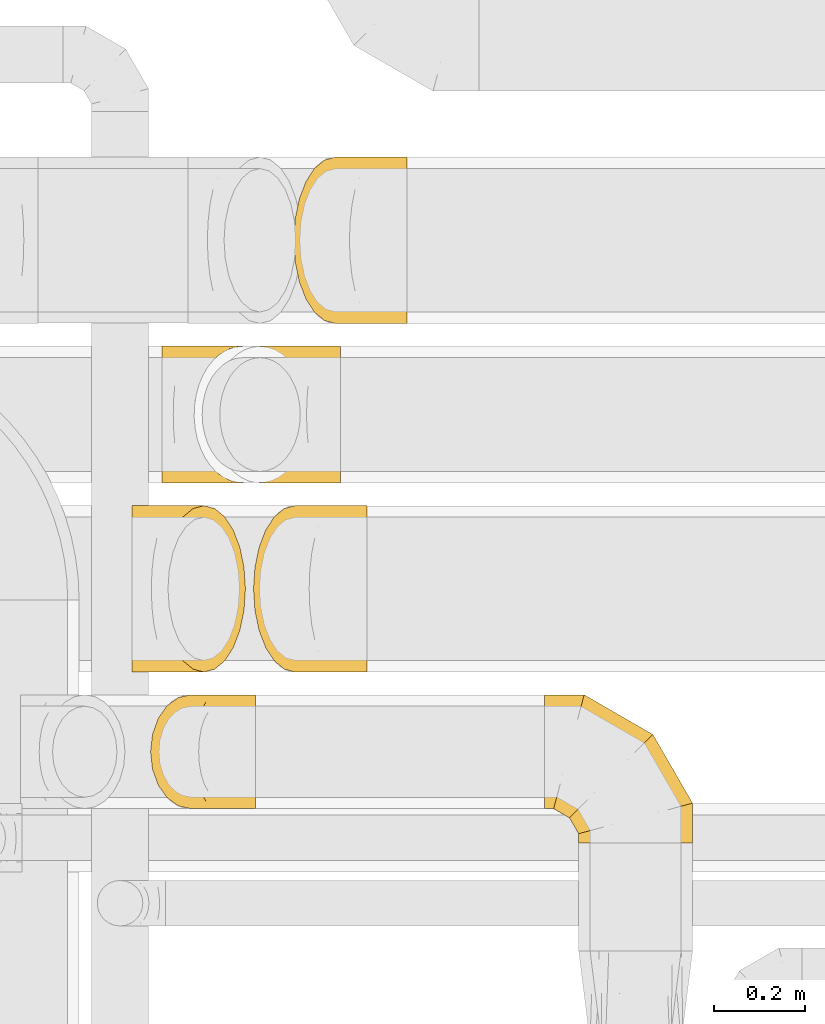
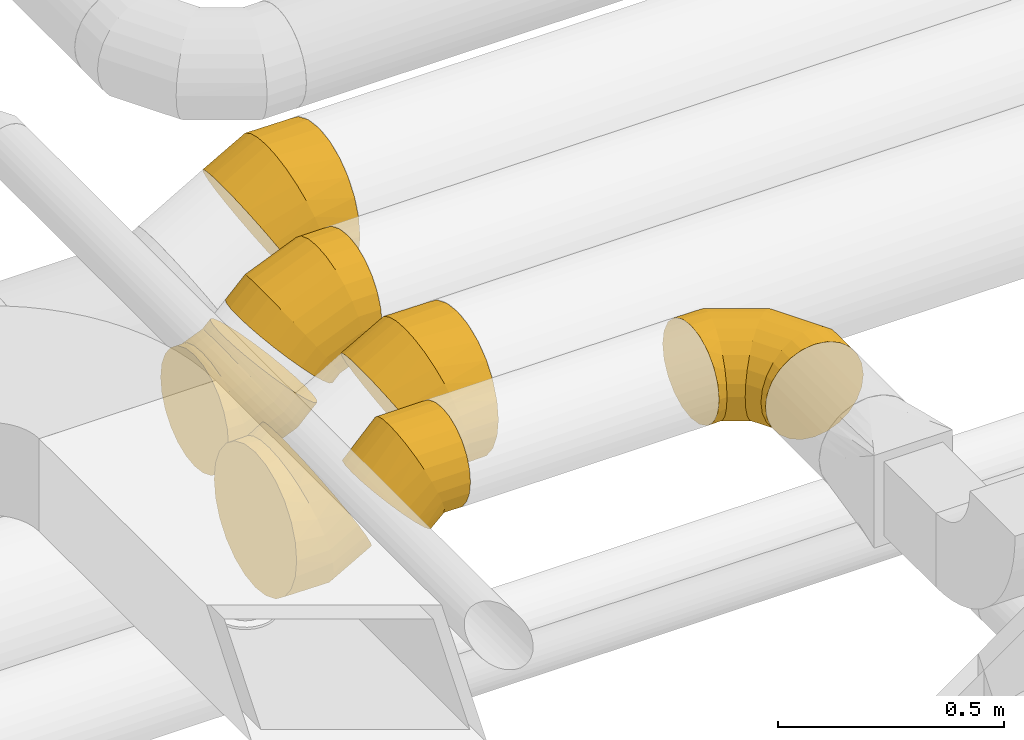
# One storey, part 22 of 92: 7 coverings.
"""IFC2X3 building model written with IfcOpenShell, lengths in millimetres."""

import ifcopenshell
import ifcopenshell.guid

model = None  # the IFC model being written
_history = None  # IfcOwnerHistory: only IFC2X3 demands one
_inside = {}  # id of a spatial element -> (the spatial element, [elements in it])
_under = {}  # id of a project, library or spatial element -> (it, [spatial elements below it])
_declared = {}  # id of a project -> (the project, [libraries it declares])
_typed = {}  # id of a type object -> (the type object, [elements of that type])
_made_of = {}  # id of a material, layer set ... -> (it, [elements and type objects made of it])


def new_model(schema):
    """Start an empty IFC model of exactly this schema.

    Asked for "IFC4X3", IfcOpenShell would pick the latest addendum, in which some entities
    have other attributes; the version numbers below select the first issue.
    IFC2X3 requires an IfcOwnerHistory on every rooted entity: one is made here for all.
    """
    global model, _history
    if schema == "IFC4X3":
        model = ifcopenshell.file(schema_version=(4, 3, 0, 0))
    else:
        model = ifcopenshell.file(schema=schema)
    _inside.clear()
    _under.clear()
    _declared.clear()
    _typed.clear()
    _made_of.clear()
    _history = None
    if model.schema == "IFC2X3":
        org = make("IfcOrganization", Name="unknown")
        user = make(
            "IfcPersonAndOrganization",
            ThePerson=make("IfcPerson", FamilyName="unknown"),
            TheOrganization=org,
        )
        app = make(
            "IfcApplication",
            ApplicationDeveloper=org,
            Version="unknown",
            ApplicationFullName="unknown",
            ApplicationIdentifier="unknown",
        )
        _history = make(
            "IfcOwnerHistory",
            OwningUser=user,
            OwningApplication=app,
            ChangeAction="ADDED",
            CreationDate=0,
        )
    return model


def make(cls, **values):
    """One entity of the class cls with the attributes given. An attribute that is None is left unset."""
    return model.create_entity(
        cls, **{name: value for name, value in values.items() if value is not None}
    )


def entity(cls, *values):
    """Any entity or typed value of the class cls, its attributes in the order of the schema. None: left unset."""
    e = model.create_entity(cls)
    for i, value in enumerate(values):
        if value is not None:
            e[i] = value
    return e


def rooted(cls, **values):
    """An entity with a GlobalId (a new one), such as an element, a storey or a relation."""
    return make(cls, GlobalId=ifcopenshell.guid.new(), OwnerHistory=_history, **values)


def si_unit(unit_type, name, prefix=None):
    """IfcSIUnit, for example si_unit("LENGTHUNIT", "METRE", prefix="MILLI")."""
    return make("IfcSIUnit", UnitType=unit_type, Prefix=prefix, Name=name)


def converted_unit(unit_type, name, factor, base, dimensions=None, offset=None):
    """IfcConversionBasedUnit, such as the inch: factor (a typed value) times the base unit."""
    return make(
        "IfcConversionBasedUnit"
        if offset is None
        else "IfcConversionBasedUnitWithOffset",
        ConversionOffset=offset,
        Dimensions=None
        if dimensions is None
        else entity("IfcDimensionalExponents", *dimensions),
        UnitType=unit_type,
        Name=name,
        ConversionFactor=make(
            "IfcMeasureWithUnit", ValueComponent=factor, UnitComponent=base
        ),
    )


def derived_unit(unit_type, elements):
    """IfcDerivedUnit: a product of units, each with its exponent."""
    return make(
        "IfcDerivedUnit",
        Elements=[
            make("IfcDerivedUnitElement", Unit=unit, Exponent=power)
            for unit, power in elements
        ],
        UnitType=unit_type,
    )


def assignment(units):
    """IfcUnitAssignment: the units of a project."""
    return None if units is None else make("IfcUnitAssignment", Units=units)


def point(xyz):
    """IfcCartesianPoint."""
    return None if xyz is None else make("IfcCartesianPoint", Coordinates=xyz)


def direction(xyz):
    """IfcDirection."""
    return None if xyz is None else make("IfcDirection", DirectionRatios=xyz)


def frame(location, z_axis=None, x_axis=None):
    """IfcAxis2Placement3D, a coordinate frame: its origin and axes. An axis left out is left unset."""
    return make(
        "IfcAxis2Placement3D",
        Location=point(location),
        Axis=direction(z_axis),
        RefDirection=direction(x_axis),
    )


def origin():
    """The frame at (0, 0, 0) with its axes left unset."""
    return frame((0.0, 0.0, 0.0))


def place(relative_to, where):
    """IfcLocalPlacement: puts the frame where relative to a parent placement (None: the world)."""
    return make(
        "IfcLocalPlacement", PlacementRelTo=relative_to, RelativePlacement=where
    )


def context(
    kind, dimensions, precision=None, world=None, true_north=None, identifier=None
):
    """IfcGeometricRepresentationContext, for example the 3D "Model" context."""
    return make(
        "IfcGeometricRepresentationContext",
        ContextIdentifier=identifier,
        ContextType=kind,
        CoordinateSpaceDimension=dimensions,
        Precision=precision,
        WorldCoordinateSystem=world,
        TrueNorth=true_north,
    )


def subcontext(parent, identifier, kind, view, scale=None):
    """IfcGeometricRepresentationSubContext, for example "Body" below "Model"."""
    return make(
        "IfcGeometricRepresentationSubContext",
        ContextIdentifier=identifier,
        ContextType=kind,
        ParentContext=parent,
        TargetScale=scale,
        TargetView=view,
    )


def project(units=None, contexts=None):
    """IfcProject with its units and contexts."""
    return rooted(
        "IfcProject",
        Name="project",
        RepresentationContexts=contexts,
        UnitsInContext=assignment(units),
    )


def spatial(cls, under=None, at=None, **own):
    """A site, building, storey or space (cls), placed at a placement, below another one or the project."""
    s = rooted(cls, ObjectPlacement=at, **own)
    if under is not None:
        _under.setdefault(under.id(), (under, []))[1].append(s)
    return s


def faces_of(points, faces, orient=None, outer=None):
    """IfcFace entities. A face is a list of loops; a loop is a list of indices into points, from 0.

    orient and outer hold one flag for each loop. By default every Orientation is true, the
    first loop of a face is its IfcFaceOuterBound and the others are IfcFaceBound.
    """
    made = []
    for i, loops in enumerate(faces):
        bounds = []
        for j, loop in enumerate(loops):
            is_outer = j == 0 if outer is None else outer[i][j]
            bounds.append(
                make(
                    "IfcFaceOuterBound" if is_outer else "IfcFaceBound",
                    Bound=make("IfcPolyLoop", Polygon=[points[k] for k in loop]),
                    Orientation=True if orient is None else orient[i][j],
                )
            )
        made.append(make("IfcFace", Bounds=bounds))
    return made


def faceted_brep(points, faces, orient=None, outer=None, voids=None):
    """IfcFacetedBrep: a solid bounded by flat faces; with voids (closed shells), ...WithVoids."""
    shared = [point(p) for p in points]
    hull = make("IfcClosedShell", CfsFaces=faces_of(shared, faces, orient, outer))
    if voids is None:
        return make("IfcFacetedBrep", Outer=hull)
    return make(
        "IfcFacetedBrepWithVoids",
        Outer=hull,
        Voids=[
            make(cls, CfsFaces=faces_of(shared, fs, o, b)) for cls, fs, o, b in voids
        ],
    )


def shape(context_of_items, identifier, shape_type, items):
    """IfcShapeRepresentation: the items that make up one representation, for example the "Body"."""
    return make(
        "IfcShapeRepresentation",
        ContextOfItems=context_of_items,
        RepresentationIdentifier=identifier,
        RepresentationType=shape_type,
        Items=items,
    )


def made_of(thing, what):
    """Note that an element or type object is made of a material, layer set ...; save() writes the relation."""
    if what is not None:
        _made_of.setdefault(what.id(), (what, []))[1].append(thing)
    return thing


def element(
    cls,
    number,
    at=None,
    inside=None,
    cuts=None,
    type_object=None,
    material=None,
    context=None,
    identifier="Body",
    shape_type=None,
    held_by="IfcProductDefinitionShape",
    body=None,
    shapes=None,
    **own,
):
    """One element of the class cls, such as IfcWall. Its Tag is "e" and its number.

    at: its placement. inside: the storey or other place that contains it. cuts: it is an
    opening in that element (IfcRelVoidsElement). A single representation is given by context,
    identifier, shape_type and body (its items); several are given by shapes. held_by: the class
    of the entity that holds the representations. save() writes the other relations.
    """
    e = rooted(cls, Tag="e%d" % number, ObjectPlacement=at, **own)
    if body is not None:
        shapes = [shape(context, identifier, shape_type, body)]
    if shapes is not None:
        e.Representation = make(held_by, Representations=shapes)
    if inside is not None:
        _inside.setdefault(inside.id(), (inside, []))[1].append(e)
    if cuts is not None:
        rooted(
            "IfcRelVoidsElement", RelatingBuildingElement=cuts, RelatedOpeningElement=e
        )
    if type_object is not None:
        _typed.setdefault(type_object.id(), (type_object, []))[1].append(e)
    return made_of(e, material)


def aggregate(whole, parts):
    """IfcRelAggregates: a whole, such as a stair, and the parts it consists of."""
    return rooted("IfcRelAggregates", RelatingObject=whole, RelatedObjects=parts)


def save(model, path):
    """Write the relations noted so far, then the file.

    IfcRelAggregates (storeys below a building ...), IfcRelContainedInSpatialStructure (elements
    in a storey), IfcRelDefinesByType, IfcRelAssociatesMaterial and IfcRelDeclares: one each for
    every whole, place, type object, material and project.
    """
    for whole, parts in _under.values():
        aggregate(whole, parts)
    for where, things in _inside.values():
        rooted(
            "IfcRelContainedInSpatialStructure",
            RelatedElements=things,
            RelatingStructure=where,
        )
    for kind, things in _typed.values():
        rooted("IfcRelDefinesByType", RelatedObjects=things, RelatingType=kind)
    for what, things in _made_of.values():
        rooted("IfcRelAssociatesMaterial", RelatedObjects=things, RelatingMaterial=what)
    for by, libraries in _declared.values():
        rooted("IfcRelDeclares", RelatingContext=by, RelatedDefinitions=libraries)
    model.write(path)


model = new_model("IFC2X3")

# Units and contexts
model_context = context("Model", 3, precision=0.01, world=origin(), true_north=direction((6.12303176911189e-17, 1.0)))
body_context = subcontext(model_context, "Body", "Model", "MODEL_VIEW")
ifc_project = project(units=[si_unit("LENGTHUNIT", "METRE", prefix="MILLI"), si_unit("AREAUNIT", "SQUARE_METRE"), si_unit("VOLUMEUNIT", "CUBIC_METRE"), converted_unit("PLANEANGLEUNIT", "DEGREE", entity("IfcRatioMeasure", 0.0174532925199433), si_unit("PLANEANGLEUNIT", "RADIAN"), dimensions=[0, 0, 0, 0, 0, 0, 0]), si_unit("MASSUNIT", "GRAM", prefix="KILO"), derived_unit("MASSDENSITYUNIT", [(si_unit("MASSUNIT", "GRAM", prefix="KILO"), 1), (si_unit("LENGTHUNIT", "METRE"), -3)]), derived_unit("MOMENTOFINERTIAUNIT", [(si_unit("LENGTHUNIT", "METRE"), 4)]), si_unit("TIMEUNIT", "SECOND"), si_unit("FREQUENCYUNIT", "HERTZ"), si_unit("THERMODYNAMICTEMPERATUREUNIT", "DEGREE_CELSIUS"), derived_unit("THERMALTRANSMITTANCEUNIT", [(si_unit("MASSUNIT", "GRAM", prefix="KILO"), 1), (si_unit("THERMODYNAMICTEMPERATUREUNIT", "KELVIN"), -1), (si_unit("TIMEUNIT", "SECOND"), -3)]), derived_unit("VOLUMETRICFLOWRATEUNIT", [(si_unit("LENGTHUNIT", "METRE"), 3), (si_unit("TIMEUNIT", "SECOND"), -1)]), derived_unit("MASSFLOWRATEUNIT", [(si_unit("MASSUNIT", "GRAM", prefix="KILO"), 1), (si_unit("TIMEUNIT", "SECOND"), -1)]), derived_unit("ROTATIONALFREQUENCYUNIT", [(si_unit("TIMEUNIT", "SECOND"), -1)]), si_unit("ELECTRICCURRENTUNIT", "AMPERE"), si_unit("ELECTRICVOLTAGEUNIT", "VOLT"), si_unit("POWERUNIT", "WATT"), si_unit("FORCEUNIT", "NEWTON", prefix="KILO"), si_unit("ILLUMINANCEUNIT", "LUX"), si_unit("LUMINOUSFLUXUNIT", "LUMEN"), si_unit("LUMINOUSINTENSITYUNIT", "CANDELA"), derived_unit("USERDEFINED", [(si_unit("MASSUNIT", "GRAM", prefix="KILO"), -1), (si_unit("LENGTHUNIT", "METRE"), -2), (si_unit("TIMEUNIT", "SECOND"), 3), (si_unit("LUMINOUSFLUXUNIT", "LUMEN"), 1)]), derived_unit("LINEARVELOCITYUNIT", [(si_unit("LENGTHUNIT", "METRE"), 1), (si_unit("TIMEUNIT", "SECOND"), -1)]), si_unit("PRESSUREUNIT", "PASCAL"), derived_unit("USERDEFINED", [(si_unit("LENGTHUNIT", "METRE"), -2), (si_unit("MASSUNIT", "GRAM", prefix="KILO"), 1), (si_unit("TIMEUNIT", "SECOND"), -2)]), derived_unit("LINEARFORCEUNIT", [(si_unit("MASSUNIT", "GRAM", prefix="KILO"), 1), (si_unit("LENGTHUNIT", "METRE"), 1), (si_unit("TIMEUNIT", "SECOND"), -2), (si_unit("LENGTHUNIT", "METRE"), -1)]), derived_unit("PLANARFORCEUNIT", [(si_unit("MASSUNIT", "GRAM", prefix="KILO"), 1), (si_unit("LENGTHUNIT", "METRE"), 1), (si_unit("TIMEUNIT", "SECOND"), -2), (si_unit("LENGTHUNIT", "METRE"), -2)])], contexts=[model_context])

# Site, building, storey
site_placement = place(None, origin())
site = spatial("IfcSite", under=ifc_project, at=site_placement, CompositionType="ELEMENT")
building_placement = place(site_placement, origin())
building = spatial("IfcBuilding", under=site, at=building_placement, CompositionType="ELEMENT")
storey_placement = place(building_placement, frame((0.0, 0.0, 4200.0)))
storey = spatial("IfcBuildingStorey", under=building, at=storey_placement, CompositionType="ELEMENT", Elevation=4200.0)

# Coverings
covering_1_placement = place(storey_placement, frame((50726.84, 15187.9, 2938.4)))
element("IfcCovering", 1, at=covering_1_placement, inside=storey, PredefinedType="INSULATION", context=body_context, shape_type="Brep", body=[
    faceted_brep([(70.71, 151.6, 330.88), (74.32, 112.77, 327.27), (84.92, 76.6, 316.67), (101.78, 45.53, 299.82), (123.74, 21.69, 277.85), (149.32, 6.71, 252.27), (176.78, 1.6, 224.82), (204.23, 6.71, 197.37), (229.81, 21.69, 171.79), (251.78, 45.53, 149.82), (268.63, 76.6, 132.96), (279.23, 112.77, 122.37), (282.84, 151.6, 118.75), (279.23, 190.42, 122.37), (268.63, 226.6, 132.96), (251.78, 257.66, 149.82), (229.81, 281.5, 171.79), (204.23, 296.48, 197.37), (176.78, 301.6, 224.82), (149.32, 296.48, 252.27), (123.74, 281.5, 277.85), (101.78, 257.66, 299.82), (84.92, 226.6, 316.67), (74.32, 190.42, 327.27), (0.0, 226.6, 21.69), (0.0, 190.42, 6.71), (0.0, 151.6, 1.6), (0.0, 112.77, 6.71), (0.0, 76.6, 21.69), (0.0, 45.53, 45.53), (0.0, 21.69, 76.6), (0.0, 6.71, 112.77), (0.0, 1.6, 151.6), (0.0, 6.71, 190.42), (0.0, 21.69, 226.6), (0.0, 45.53, 257.66), (0.0, 76.6, 281.5), (0.0, 112.77, 296.48), (0.0, 151.6, 301.6), (0.0, 190.42, 296.48), (0.0, 226.6, 281.5), (0.0, 257.66, 257.66), (0.0, 281.5, 226.6), (0.0, 296.48, 190.42), (0.0, 301.6, 151.6), (0.0, 296.48, 112.77), (0.0, 281.5, 76.6), (0.0, 257.66, 45.53), (79.56, 151.6, 1.6), (78.55, 112.77, 6.71), (75.57, 76.6, 21.69), (70.83, 45.53, 45.53), (64.65, 21.69, 76.6), (57.45, 6.71, 112.77), (49.73, 1.6, 151.6), (42.01, 6.71, 190.42), (34.81, 21.69, 226.6), (28.63, 45.53, 257.66), (23.89, 76.6, 281.5), (20.91, 112.77, 296.48), (19.89, 151.6, 301.6), (20.91, 190.42, 296.48), (23.89, 226.6, 281.5), (28.63, 257.66, 257.66), (42.01, 296.48, 190.42), (49.73, 301.6, 151.6), (34.81, 281.5, 226.6), (57.45, 296.48, 112.77), (64.65, 281.5, 76.6), (70.83, 257.66, 45.53), (75.57, 226.6, 21.69), (78.55, 190.42, 6.71), (226.58, 151.6, 62.49), (223.69, 112.77, 66.82), (215.2, 76.6, 79.53), (201.7, 45.53, 99.74), (184.1, 21.69, 126.07), (163.61, 6.71, 156.74), (141.61, 1.6, 189.66), (119.62, 6.71, 222.57), (99.13, 21.69, 253.24), (81.53, 45.53, 279.57), (68.03, 76.6, 299.78), (59.54, 112.77, 312.49), (56.65, 151.6, 316.82), (59.54, 190.42, 312.49), (68.03, 226.6, 299.78), (81.53, 257.66, 279.57), (119.62, 296.48, 222.57), (141.61, 301.6, 189.66), (99.13, 281.5, 253.24), (163.61, 296.48, 156.74), (184.1, 281.5, 126.07), (201.7, 257.66, 99.74), (215.2, 226.6, 79.53), (223.69, 190.42, 66.82)], [[[0, 1, 2, 3, 4, 5, 6, 7, 8, 9, 10, 11, 12, 13, 14, 15, 16, 17, 18, 19, 20, 21, 22, 23]], [[24, 25, 26, 27, 28, 29, 30, 31, 32, 33, 34, 35, 36, 37, 38, 39, 40, 41, 42, 43, 44, 45, 46, 47]], [[26, 48, 49, 27]], [[27, 49, 50, 28]], [[51, 29, 28, 50]], [[29, 51, 52, 30]], [[30, 52, 53, 31]], [[54, 32, 31, 53]], [[55, 56, 34, 33]], [[54, 55, 33, 32]], [[57, 35, 34, 56]], [[58, 59, 37, 36]], [[58, 36, 35, 57]], [[60, 38, 37, 59]], [[61, 62, 40, 39]], [[60, 61, 39, 38]], [[41, 40, 62, 63]], [[64, 65, 44, 43]], [[66, 64, 43, 42]], [[63, 66, 42, 41]], [[45, 44, 65, 67]], [[46, 45, 67, 68]], [[47, 46, 68, 69]], [[25, 24, 70, 71]], [[26, 25, 71, 48]], [[69, 70, 24, 47]], [[49, 48, 72, 73]], [[50, 49, 73, 74]], [[74, 75, 51, 50]], [[52, 51, 75, 76]], [[53, 52, 76, 77]], [[54, 53, 77, 78]], [[79, 80, 56, 55]], [[78, 79, 55, 54]], [[57, 56, 80, 81]], [[82, 83, 59, 58]], [[81, 82, 58, 57]], [[60, 59, 83, 84]], [[85, 86, 62, 61]], [[84, 85, 61, 60]], [[63, 62, 86, 87]], [[88, 89, 65, 64]], [[90, 88, 64, 66]], [[87, 90, 66, 63]], [[67, 65, 89, 91]], [[68, 67, 91, 92]], [[69, 68, 92, 93]], [[71, 70, 94, 95]], [[48, 71, 95, 72]], [[93, 94, 70, 69]], [[73, 72, 12, 11]], [[74, 73, 11, 10]], [[10, 9, 75, 74]], [[77, 76, 8, 7]], [[78, 77, 7, 6]], [[9, 8, 76, 75]], [[79, 78, 6, 5]], [[80, 79, 5, 4]], [[81, 80, 4, 3]], [[83, 82, 2, 1]], [[84, 83, 1, 0]], [[81, 3, 2, 82]], [[84, 0, 23, 85]], [[85, 23, 22, 86]], [[86, 22, 21, 87]], [[90, 20, 19, 88]], [[88, 19, 18, 89]], [[90, 87, 21, 20]], [[17, 16, 92, 91]], [[18, 17, 91, 89]], [[15, 93, 92, 16]], [[94, 14, 13, 95]], [[95, 13, 12, 72]], [[14, 94, 93, 15]]]),
])
covering_2_placement = place(storey_placement, frame((50834.51, 15187.9, 3094.12)))
element("IfcCovering", 2, at=covering_2_placement, inside=storey, PredefinedType="INSULATION", context=body_context, shape_type="Brep", body=[
    faceted_brep([(284.44, 190.42, 36.0), (284.44, 226.6, 50.98), (284.44, 257.66, 74.82), (284.44, 281.5, 105.88), (284.44, 296.48, 142.06), (284.44, 301.6, 180.88), (284.44, 296.48, 219.71), (284.44, 281.5, 255.88), (284.44, 257.66, 286.95), (284.44, 226.6, 310.79), (284.44, 190.42, 325.77), (284.44, 151.6, 330.88), (284.44, 112.77, 325.77), (284.44, 76.6, 310.79), (284.44, 45.53, 286.95), (284.44, 21.69, 255.88), (284.44, 6.71, 219.71), (284.44, 1.6, 180.88), (284.44, 6.71, 142.06), (284.44, 21.69, 105.88), (284.44, 45.53, 74.82), (284.44, 76.6, 50.98), (284.44, 112.77, 36.0), (284.44, 151.6, 30.88), (15.81, 76.6, 199.52), (5.21, 112.77, 210.11), (1.6, 151.6, 213.73), (5.21, 190.42, 210.11), (15.81, 226.6, 199.52), (32.66, 257.66, 182.66), (54.63, 281.5, 160.69), (80.21, 296.48, 135.11), (107.66, 301.6, 107.66), (135.11, 296.48, 80.21), (160.69, 281.5, 54.63), (182.66, 257.66, 32.66), (199.52, 226.6, 15.81), (210.11, 190.42, 5.21), (213.73, 151.6, 1.6), (210.11, 112.77, 5.21), (199.52, 76.6, 15.81), (182.66, 45.53, 32.66), (160.69, 21.69, 54.63), (135.11, 6.71, 80.21), (107.66, 1.6, 107.66), (80.21, 6.71, 135.11), (54.63, 21.69, 160.69), (32.66, 45.53, 182.66), (57.86, 151.6, 269.99), (60.75, 190.42, 265.66), (69.24, 226.6, 252.95), (82.74, 257.66, 232.74), (100.34, 281.5, 206.41), (120.83, 296.48, 175.74), (142.82, 301.6, 142.82), (164.82, 296.48, 109.91), (185.31, 281.5, 79.24), (202.91, 257.66, 52.91), (216.41, 226.6, 32.7), (224.9, 190.42, 19.99), (227.79, 151.6, 15.66), (224.9, 112.77, 19.99), (216.41, 76.6, 32.7), (202.91, 45.53, 52.91), (164.82, 6.71, 109.91), (142.82, 1.6, 142.82), (185.31, 21.69, 79.24), (120.83, 6.71, 175.74), (100.34, 21.69, 206.41), (82.74, 45.53, 232.74), (69.24, 76.6, 252.95), (60.75, 112.77, 265.66), (204.87, 151.6, 330.88), (205.89, 190.42, 325.77), (208.87, 226.6, 310.79), (213.61, 257.66, 286.95), (219.79, 281.5, 255.88), (226.99, 296.48, 219.71), (234.71, 301.6, 180.88), (242.43, 296.48, 142.06), (249.63, 281.5, 105.88), (255.81, 257.66, 74.82), (260.55, 226.6, 50.98), (263.53, 190.42, 36.0), (264.55, 151.6, 30.88), (263.53, 112.77, 36.0), (260.55, 76.6, 50.98), (255.81, 45.53, 74.82), (242.43, 6.71, 142.06), (234.71, 1.6, 180.88), (249.63, 21.69, 105.88), (226.99, 6.71, 219.71), (219.79, 21.69, 255.88), (213.61, 45.53, 286.95), (208.87, 76.6, 310.79), (205.89, 112.77, 325.77)], [[[0, 1, 2, 3, 4, 5, 6, 7, 8, 9, 10, 11, 12, 13, 14, 15, 16, 17, 18, 19, 20, 21, 22, 23]], [[24, 25, 26, 27, 28, 29, 30, 31, 32, 33, 34, 35, 36, 37, 38, 39, 40, 41, 42, 43, 44, 45, 46, 47]], [[26, 48, 49, 27]], [[27, 49, 50, 28]], [[51, 29, 28, 50]], [[29, 51, 52, 30]], [[30, 52, 53, 31]], [[54, 32, 31, 53]], [[55, 56, 34, 33]], [[54, 55, 33, 32]], [[57, 35, 34, 56]], [[58, 59, 37, 36]], [[58, 36, 35, 57]], [[60, 38, 37, 59]], [[61, 62, 40, 39]], [[60, 61, 39, 38]], [[41, 40, 62, 63]], [[64, 65, 44, 43]], [[66, 64, 43, 42]], [[63, 66, 42, 41]], [[45, 44, 65, 67]], [[46, 45, 67, 68]], [[47, 46, 68, 69]], [[25, 24, 70, 71]], [[26, 25, 71, 48]], [[69, 70, 24, 47]], [[49, 48, 72, 73]], [[50, 49, 73, 74]], [[74, 75, 51, 50]], [[52, 51, 75, 76]], [[53, 52, 76, 77]], [[54, 53, 77, 78]], [[79, 80, 56, 55]], [[78, 79, 55, 54]], [[57, 56, 80, 81]], [[82, 83, 59, 58]], [[81, 82, 58, 57]], [[60, 59, 83, 84]], [[85, 86, 62, 61]], [[84, 85, 61, 60]], [[63, 62, 86, 87]], [[88, 89, 65, 64]], [[90, 88, 64, 66]], [[87, 90, 66, 63]], [[67, 65, 89, 91]], [[68, 67, 91, 92]], [[69, 68, 92, 93]], [[71, 70, 94, 95]], [[48, 71, 95, 72]], [[93, 94, 70, 69]], [[73, 72, 11, 10]], [[74, 73, 10, 9]], [[9, 8, 75, 74]], [[77, 76, 7, 6]], [[78, 77, 6, 5]], [[8, 7, 76, 75]], [[79, 78, 5, 4]], [[80, 79, 4, 3]], [[81, 80, 3, 2]], [[83, 82, 1, 0]], [[84, 83, 0, 23]], [[81, 2, 1, 82]], [[84, 23, 22, 85]], [[85, 22, 21, 86]], [[86, 21, 20, 87]], [[90, 19, 18, 88]], [[88, 18, 17, 89]], [[90, 87, 20, 19]], [[16, 15, 92, 91]], [[17, 16, 91, 89]], [[14, 93, 92, 15]], [[94, 13, 12, 95]], [[95, 12, 11, 72]], [[13, 94, 93, 14]]]),
])
covering_3_placement = place(storey_placement, frame((51566.52, 14399.5, 3223.4)))
element("IfcCovering", 3, at=covering_3_placement, inside=storey, PredefinedType="INSULATION", context=body_context, shape_type="Brep", body=[
    faceted_brep([(0.0, 200.0, 251.6), (0.0, 238.63, 245.48), (0.0, 273.47, 227.72), (0.0, 301.13, 200.07), (0.0, 318.88, 165.22), (0.0, 325.0, 126.6), (0.0, 318.88, 87.97), (0.0, 301.13, 53.12), (0.0, 273.47, 25.47), (0.0, 238.63, 7.71), (0.0, 200.0, 1.6), (0.0, 161.37, 7.71), (0.0, 126.53, 25.47), (0.0, 98.87, 53.12), (0.0, 81.12, 87.97), (0.0, 75.0, 126.6), (0.0, 81.12, 165.22), (0.0, 98.87, 200.07), (0.0, 126.53, 227.72), (0.0, 161.37, 245.48), (308.25, 0.0, 64.1), (320.74, 0.0, 94.24), (325.0, 0.0, 126.6), (320.74, 0.0, 158.95), (308.25, 0.0, 189.1), (288.39, 0.0, 214.98), (262.5, 0.0, 234.85), (232.35, 0.0, 247.34), (200.0, 0.0, 251.6), (167.65, 0.0, 247.34), (137.5, 0.0, 234.85), (111.61, 0.0, 214.98), (91.75, 0.0, 189.1), (79.26, 0.0, 158.95), (75.0, 0.0, 126.6), (79.26, 0.0, 94.24), (91.75, 0.0, 64.1), (111.61, 0.0, 38.21), (137.5, 0.0, 18.34), (167.65, 0.0, 5.85), (200.0, 0.0, 1.6), (232.35, 0.0, 5.85), (262.5, 0.0, 18.34), (288.39, 0.0, 38.21), (325.0, 87.08, 126.6), (320.74, 85.94, 158.95), (308.25, 82.6, 189.1), (288.39, 77.27, 214.98), (262.5, 70.34, 234.85), (232.35, 62.26, 247.34), (200.0, 53.59, 251.6), (167.65, 44.92, 247.34), (137.5, 36.84, 234.85), (111.61, 29.91, 214.98), (91.75, 24.58, 189.1), (79.26, 21.24, 158.95), (75.0, 20.1, 126.6), (79.26, 21.24, 94.24), (91.75, 24.58, 64.1), (111.61, 29.91, 38.21), (167.65, 44.92, 5.85), (200.0, 53.59, 1.6), (137.5, 36.84, 18.34), (232.35, 62.26, 5.85), (262.5, 70.34, 18.34), (288.39, 77.27, 38.21), (308.25, 82.6, 64.1), (320.74, 85.94, 94.24), (237.92, 237.92, 126.6), (234.8, 234.8, 158.95), (225.66, 225.66, 189.1), (211.11, 211.11, 214.98), (192.16, 192.16, 234.85), (170.09, 170.09, 247.34), (146.41, 146.41, 251.6), (122.73, 122.73, 247.34), (100.66, 100.66, 234.85), (81.71, 81.71, 214.98), (67.16, 67.16, 189.1), (58.02, 58.02, 158.95), (54.9, 54.9, 126.6), (58.02, 58.02, 94.24), (67.16, 67.16, 64.1), (81.71, 81.71, 38.21), (122.73, 122.73, 5.85), (146.41, 146.41, 1.6), (100.66, 100.66, 18.34), (170.09, 170.09, 5.85), (192.16, 192.16, 18.34), (211.11, 211.11, 38.21), (225.66, 225.66, 64.1), (234.8, 234.8, 94.24), (87.08, 325.0, 126.6), (85.94, 320.74, 158.95), (82.6, 308.25, 189.1), (77.27, 288.39, 214.98), (70.34, 262.5, 234.85), (62.26, 232.35, 247.34), (53.59, 200.0, 251.6), (44.92, 167.65, 247.34), (36.84, 137.5, 234.85), (29.91, 111.61, 214.98), (24.58, 91.75, 189.1), (21.24, 79.26, 158.95), (20.1, 75.0, 126.6), (21.24, 79.26, 94.24), (24.58, 91.75, 64.1), (29.91, 111.61, 38.21), (44.92, 167.65, 5.85), (53.59, 200.0, 1.6), (36.84, 137.5, 18.34), (62.26, 232.35, 5.85), (70.34, 262.5, 18.34), (77.27, 288.39, 38.21), (82.6, 308.25, 64.1), (85.94, 320.74, 94.24)], [[[0, 1, 2, 3, 4, 5, 6, 7, 8, 9, 10, 11, 12, 13, 14, 15, 16, 17, 18, 19]], [[20, 21, 22, 23, 24, 25, 26, 27, 28, 29, 30, 31, 32, 33, 34, 35, 36, 37, 38, 39, 40, 41, 42, 43]], [[22, 44, 45, 23]], [[23, 45, 46, 24]], [[47, 25, 24, 46]], [[25, 47, 48, 26]], [[26, 48, 49, 27]], [[50, 28, 27, 49]], [[51, 52, 30, 29]], [[50, 51, 29, 28]], [[53, 31, 30, 52]], [[54, 55, 33, 32]], [[54, 32, 31, 53]], [[56, 34, 33, 55]], [[57, 58, 36, 35]], [[56, 57, 35, 34]], [[37, 36, 58, 59]], [[60, 61, 40, 39]], [[62, 60, 39, 38]], [[59, 62, 38, 37]], [[41, 40, 61, 63]], [[42, 41, 63, 64]], [[64, 65, 43, 42]], [[21, 20, 66, 67]], [[22, 21, 67, 44]], [[65, 66, 20, 43]], [[45, 44, 68, 69]], [[46, 45, 69, 70]], [[70, 71, 47, 46]], [[48, 47, 71, 72]], [[49, 48, 72, 73]], [[50, 49, 73, 74]], [[75, 76, 52, 51]], [[74, 75, 51, 50]], [[53, 52, 76, 77]], [[78, 79, 55, 54]], [[77, 78, 54, 53]], [[56, 55, 79, 80]], [[81, 82, 58, 57]], [[80, 81, 57, 56]], [[59, 58, 82, 83]], [[84, 85, 61, 60]], [[86, 84, 60, 62]], [[83, 86, 62, 59]], [[63, 61, 85, 87]], [[64, 63, 87, 88]], [[65, 64, 88, 89]], [[67, 66, 90, 91]], [[44, 67, 91, 68]], [[89, 90, 66, 65]], [[69, 68, 92, 93]], [[70, 69, 93, 94]], [[94, 95, 71, 70]], [[72, 71, 95, 96]], [[73, 72, 96, 97]], [[74, 73, 97, 98]], [[99, 100, 76, 75]], [[98, 99, 75, 74]], [[77, 76, 100, 101]], [[102, 103, 79, 78]], [[101, 102, 78, 77]], [[80, 79, 103, 104]], [[105, 106, 82, 81]], [[104, 105, 81, 80]], [[83, 82, 106, 107]], [[108, 109, 85, 84]], [[110, 108, 84, 86]], [[107, 110, 86, 83]], [[87, 85, 109, 111]], [[88, 87, 111, 112]], [[89, 88, 112, 113]], [[91, 90, 114, 115]], [[68, 91, 115, 92]], [[113, 114, 90, 89]], [[93, 5, 4]], [[94, 4, 3]], [[5, 93, 92]], [[93, 4, 94]], [[3, 95, 94]], [[96, 2, 1]], [[97, 1, 0]], [[95, 2, 96]], [[96, 1, 97]], [[0, 98, 97]], [[2, 95, 3]], [[99, 0, 19]], [[100, 19, 18]], [[99, 98, 0]], [[100, 99, 19]], [[18, 101, 100]], [[16, 15, 103]], [[17, 16, 102]], [[102, 101, 17]], [[104, 103, 15]], [[102, 16, 103]], [[17, 101, 18]], [[105, 15, 14]], [[106, 14, 13]], [[105, 104, 15]], [[106, 105, 14]], [[13, 107, 106]], [[110, 12, 11]], [[108, 11, 10]], [[110, 107, 12]], [[109, 108, 10]], [[110, 11, 108]], [[12, 107, 13]], [[111, 10, 9]], [[112, 9, 8]], [[10, 111, 109]], [[111, 9, 112]], [[8, 113, 112]], [[114, 7, 6]], [[115, 6, 5]], [[113, 7, 114]], [[115, 114, 6]], [[92, 115, 5]], [[7, 113, 8]]]),
])
covering_4_placement = place(storey_placement, frame((50700.36, 14472.9, 3201.44)))
element("IfcCovering", 4, at=covering_4_placement, inside=storey, PredefinedType="INSULATION", context=body_context, shape_type="Brep", body=[
    faceted_brep([(178.37, 126.6, 1.6), (174.05, 87.97, 5.92), (161.49, 53.12, 18.48), (141.94, 25.47, 38.03), (117.3, 7.71, 62.67), (89.98, 1.6, 89.98), (62.67, 7.71, 117.3), (38.03, 25.47, 141.94), (18.48, 53.12, 161.49), (5.92, 87.97, 174.05), (1.6, 126.6, 178.37), (5.92, 165.22, 174.05), (18.48, 200.07, 161.49), (38.03, 227.72, 141.94), (62.67, 245.48, 117.3), (89.98, 251.6, 89.98), (117.3, 245.48, 62.67), (141.94, 227.72, 38.03), (161.49, 200.07, 18.48), (174.05, 165.22, 5.92), (231.4, 158.95, 269.3), (231.4, 126.6, 273.56), (231.4, 94.24, 269.3), (231.4, 64.1, 256.82), (231.4, 38.21, 236.95), (231.4, 18.34, 211.06), (231.4, 5.85, 180.91), (231.4, 1.6, 148.56), (231.4, 5.85, 116.21), (231.4, 18.34, 86.06), (231.4, 38.21, 60.17), (231.4, 64.1, 40.31), (231.4, 94.24, 27.82), (231.4, 126.6, 23.56), (231.4, 158.95, 27.82), (231.4, 189.1, 40.31), (231.4, 214.98, 60.17), (231.4, 234.85, 86.06), (231.4, 247.34, 116.21), (231.4, 251.6, 148.56), (231.4, 247.34, 180.91), (231.4, 234.85, 211.06), (231.4, 214.98, 236.95), (231.4, 189.1, 256.82), (96.79, 126.6, 273.56), (98.55, 94.24, 269.3), (103.72, 64.1, 256.82), (111.95, 38.21, 236.95), (122.67, 18.34, 211.06), (135.16, 5.85, 180.91), (148.56, 1.6, 148.56), (161.96, 5.85, 116.21), (174.45, 18.34, 86.06), (185.17, 38.21, 60.17), (198.57, 94.24, 27.82), (200.34, 126.6, 23.56), (193.4, 64.1, 40.31), (193.4, 189.1, 40.31), (185.17, 214.98, 60.17), (198.57, 158.95, 27.82), (161.96, 247.34, 116.21), (148.56, 251.6, 148.56), (174.45, 234.85, 86.06), (135.16, 247.34, 180.91), (122.67, 234.85, 211.06), (111.95, 214.98, 236.95), (103.72, 189.1, 256.82), (98.55, 158.95, 269.3)], [[[0, 1, 2, 3, 4, 5, 6, 7, 8, 9, 10, 11, 12, 13, 14, 15, 16, 17, 18, 19]], [[20, 21, 22, 23, 24, 25, 26, 27, 28, 29, 30, 31, 32, 33, 34, 35, 36, 37, 38, 39, 40, 41, 42, 43]], [[21, 44, 45, 22]], [[22, 45, 46, 23]], [[47, 24, 23, 46]], [[24, 47, 48, 25]], [[25, 48, 49, 26]], [[50, 27, 26, 49]], [[51, 52, 29, 28]], [[50, 51, 28, 27]], [[29, 52, 53, 30]], [[54, 55, 33, 32]], [[56, 54, 32, 31]], [[30, 53, 56, 31]], [[35, 57, 58, 36]], [[59, 57, 35, 34]], [[33, 55, 59, 34]], [[60, 61, 39, 38]], [[62, 60, 38, 37]], [[58, 62, 37, 36]], [[40, 39, 61, 63]], [[41, 40, 63, 64]], [[64, 65, 42, 41]], [[20, 43, 66, 67]], [[21, 20, 67, 44]], [[65, 66, 43, 42]], [[9, 8, 46]], [[10, 9, 45]], [[10, 45, 44]], [[45, 9, 46]], [[8, 47, 46]], [[48, 7, 6]], [[49, 6, 5]], [[47, 7, 48]], [[48, 6, 49]], [[5, 50, 49]], [[7, 47, 8]], [[4, 3, 52]], [[5, 4, 51]], [[51, 50, 5]], [[52, 51, 4]], [[3, 53, 52]], [[56, 2, 1]], [[54, 1, 0]], [[56, 53, 2]], [[55, 54, 0]], [[56, 1, 54]], [[2, 53, 3]], [[19, 18, 57]], [[0, 19, 59]], [[59, 55, 0]], [[57, 59, 19]], [[18, 58, 57]], [[62, 17, 16]], [[60, 16, 15]], [[62, 58, 17]], [[61, 60, 15]], [[62, 16, 60]], [[17, 58, 18]], [[63, 15, 14]], [[64, 14, 13]], [[15, 63, 61]], [[63, 14, 64]], [[13, 65, 64]], [[66, 12, 11]], [[67, 11, 10]], [[65, 12, 66]], [[67, 66, 11]], [[44, 67, 10]], [[12, 65, 13]]]),
])
covering_5_placement = place(storey_placement, frame((51014.71, 15537.91, 3048.15)))
element("IfcCovering", 5, at=covering_5_placement, inside=storey, PredefinedType="INSULATION", context=body_context, shape_type="Brep", body=[
    faceted_brep([(184.1, 184.1, 1.6), (180.99, 136.86, 6.98), (171.87, 92.85, 22.77), (157.37, 55.05, 47.89), (138.47, 26.05, 80.62), (116.46, 7.81, 118.74), (92.85, 1.6, 159.64), (69.23, 7.81, 200.55), (47.22, 26.05, 238.67), (28.32, 55.05, 271.4), (13.82, 92.85, 296.52), (4.7, 136.86, 312.31), (1.6, 184.1, 317.69), (4.7, 231.33, 312.31), (13.82, 275.35, 296.52), (28.32, 313.14, 271.4), (47.22, 342.14, 238.67), (69.23, 360.38, 200.55), (92.85, 366.6, 159.64), (116.46, 360.38, 118.74), (138.47, 342.14, 80.62), (157.37, 313.14, 47.89), (171.87, 275.35, 22.77), (180.99, 231.33, 6.98), (250.35, 275.35, 359.9), (250.35, 231.33, 378.13), (250.35, 184.1, 384.35), (250.35, 136.86, 378.13), (250.35, 92.85, 359.9), (250.35, 55.05, 330.89), (250.35, 26.05, 293.1), (250.35, 7.81, 249.08), (250.35, 1.6, 201.85), (250.35, 7.81, 154.61), (250.35, 26.05, 110.6), (250.35, 55.05, 72.8), (250.35, 92.85, 43.8), (250.35, 136.86, 25.57), (250.35, 184.1, 19.35), (250.35, 231.33, 25.57), (250.35, 275.35, 43.8), (250.35, 313.14, 72.8), (250.35, 342.14, 110.6), (250.35, 360.38, 154.61), (250.35, 366.6, 201.85), (250.35, 360.38, 249.08), (250.35, 342.14, 293.1), (250.35, 313.14, 330.89), (117.04, 184.1, 384.35), (118.27, 143.49, 379.77), (121.88, 104.91, 366.27), (127.71, 70.31, 344.53), (135.45, 41.41, 315.63), (144.72, 19.67, 281.03), (155.06, 6.17, 242.46), (165.94, 1.6, 201.85), (176.82, 6.17, 161.24), (187.16, 19.67, 122.66), (196.43, 41.41, 88.06), (204.17, 70.31, 59.16), (210.0, 104.91, 37.42), (213.62, 143.49, 23.92), (214.84, 184.1, 19.35), (210.0, 263.28, 37.42), (204.17, 297.88, 59.16), (213.62, 224.71, 23.92), (196.43, 326.78, 88.06), (187.16, 348.52, 122.66), (176.82, 362.02, 161.24), (165.94, 366.6, 201.85), (155.06, 362.02, 242.46), (144.72, 348.52, 281.03), (135.45, 326.78, 315.63), (127.71, 297.88, 344.53), (121.88, 263.28, 366.27), (118.27, 224.71, 379.77)], [[[0, 1, 2, 3, 4, 5, 6, 7, 8, 9, 10, 11, 12, 13, 14, 15, 16, 17, 18, 19, 20, 21, 22, 23]], [[24, 25, 26, 27, 28, 29, 30, 31, 32, 33, 34, 35, 36, 37, 38, 39, 40, 41, 42, 43, 44, 45, 46, 47]], [[26, 48, 49]], [[27, 49, 50]], [[26, 49, 27]], [[28, 51, 29]], [[28, 27, 50]], [[51, 28, 50]], [[30, 52, 53]], [[31, 53, 54]], [[32, 54, 55]], [[29, 52, 30]], [[30, 53, 31]], [[54, 32, 31]], [[52, 29, 51]], [[56, 57, 33]], [[55, 56, 32]], [[32, 56, 33]], [[34, 58, 35]], [[34, 33, 57]], [[58, 34, 57]], [[59, 60, 36]], [[61, 62, 38]], [[60, 61, 37]], [[35, 59, 36]], [[36, 60, 37]], [[61, 38, 37]], [[59, 35, 58]], [[63, 64, 40]], [[65, 63, 39]], [[62, 65, 38]], [[38, 65, 39]], [[63, 40, 39]], [[64, 41, 40]], [[66, 67, 42]], [[68, 69, 44]], [[67, 68, 43]], [[41, 66, 42]], [[42, 67, 43]], [[68, 44, 43]], [[66, 41, 64]], [[45, 70, 71]], [[46, 71, 72]], [[69, 70, 44]], [[44, 70, 45]], [[71, 46, 45]], [[72, 47, 46]], [[24, 73, 74]], [[74, 75, 25]], [[48, 26, 75]], [[47, 73, 24]], [[24, 74, 25]], [[75, 26, 25]], [[73, 47, 72]], [[49, 12, 11]], [[50, 11, 10]], [[48, 12, 49]], [[49, 11, 50]], [[10, 51, 50]], [[10, 9, 51]], [[52, 9, 8]], [[53, 8, 7]], [[54, 7, 6]], [[52, 8, 53]], [[53, 7, 54]], [[6, 55, 54]], [[9, 52, 51]], [[56, 6, 5]], [[57, 5, 4]], [[56, 55, 6]], [[58, 57, 4]], [[56, 5, 57]], [[4, 3, 58]], [[59, 3, 2]], [[60, 2, 1]], [[61, 1, 0]], [[60, 59, 2]], [[62, 61, 0]], [[60, 1, 61]], [[3, 59, 58]], [[65, 0, 23]], [[63, 23, 22]], [[65, 62, 0]], [[64, 63, 22]], [[65, 23, 63]], [[22, 21, 64]], [[66, 21, 20]], [[67, 20, 19]], [[68, 19, 18]], [[67, 66, 20]], [[69, 68, 18]], [[67, 19, 68]], [[21, 66, 64]], [[70, 18, 17]], [[71, 17, 16]], [[69, 18, 70]], [[71, 70, 17]], [[72, 71, 16]], [[16, 15, 72]], [[73, 15, 14]], [[74, 14, 13]], [[75, 13, 12]], [[73, 14, 74]], [[75, 74, 13]], [[48, 75, 12]], [[15, 73, 72]]]),
])
covering_6_placement = place(storey_placement, frame((50661.41, 14772.9, 2865.9)))
element("IfcCovering", 6, at=covering_6_placement, inside=storey, PredefinedType="INSULATION", context=body_context, shape_type="Brep", body=[
    faceted_brep([(66.25, 184.1, 384.35), (69.36, 136.86, 378.96), (78.48, 92.85, 363.17), (92.98, 55.05, 338.06), (111.88, 26.05, 305.32), (133.88, 7.81, 267.2), (157.5, 1.6, 226.3), (181.12, 7.81, 185.39), (203.13, 26.05, 147.27), (222.02, 55.05, 114.54), (236.52, 92.85, 89.42), (245.64, 136.86, 73.63), (248.75, 184.1, 68.25), (245.64, 231.33, 73.63), (236.52, 275.35, 89.42), (222.02, 313.14, 114.54), (203.13, 342.14, 147.27), (181.12, 360.38, 185.39), (157.5, 366.6, 226.3), (133.88, 360.38, 267.2), (111.88, 342.14, 305.32), (92.98, 313.14, 338.06), (78.48, 275.35, 363.17), (69.36, 231.33, 378.96), (0.0, 275.35, 26.05), (0.0, 231.33, 7.81), (0.0, 184.1, 1.6), (0.0, 136.86, 7.81), (0.0, 92.85, 26.05), (0.0, 55.05, 55.05), (0.0, 26.05, 92.85), (0.0, 7.81, 136.86), (0.0, 1.6, 184.1), (0.0, 7.81, 231.33), (0.0, 26.05, 275.35), (0.0, 55.05, 313.14), (0.0, 92.85, 342.14), (0.0, 136.86, 360.38), (0.0, 184.1, 366.6), (0.0, 231.33, 360.38), (0.0, 275.35, 342.14), (0.0, 313.14, 313.14), (0.0, 342.14, 275.35), (0.0, 360.38, 231.33), (0.0, 366.6, 184.1), (0.0, 360.38, 136.86), (0.0, 342.14, 92.85), (0.0, 313.14, 55.05), (133.3, 184.1, 1.6), (132.08, 143.49, 6.17), (128.46, 104.91, 19.67), (122.64, 70.31, 41.41), (114.89, 41.41, 70.31), (105.62, 19.67, 104.91), (95.29, 6.17, 143.49), (84.4, 1.6, 184.1), (73.52, 6.17, 224.71), (63.19, 19.67, 263.28), (53.91, 41.41, 297.88), (46.17, 70.31, 326.78), (40.35, 104.91, 348.52), (36.73, 143.49, 362.02), (35.5, 184.1, 366.6), (40.35, 263.28, 348.52), (46.17, 297.88, 326.78), (36.73, 224.71, 362.02), (53.91, 326.78, 297.88), (63.19, 348.52, 263.28), (73.52, 362.02, 224.71), (84.4, 366.6, 184.1), (95.29, 362.02, 143.49), (105.62, 348.52, 104.91), (114.89, 326.78, 70.31), (122.64, 297.88, 41.41), (128.46, 263.28, 19.67), (132.08, 224.71, 6.17)], [[[0, 1, 2, 3, 4, 5, 6, 7, 8, 9, 10, 11, 12, 13, 14, 15, 16, 17, 18, 19, 20, 21, 22, 23]], [[24, 25, 26, 27, 28, 29, 30, 31, 32, 33, 34, 35, 36, 37, 38, 39, 40, 41, 42, 43, 44, 45, 46, 47]], [[26, 48, 49]], [[27, 49, 50]], [[26, 49, 27]], [[28, 51, 29]], [[28, 27, 50]], [[51, 28, 50]], [[30, 52, 53]], [[31, 53, 54]], [[32, 54, 55]], [[29, 52, 30]], [[30, 53, 31]], [[54, 32, 31]], [[52, 29, 51]], [[56, 57, 33]], [[55, 56, 32]], [[32, 56, 33]], [[34, 58, 35]], [[34, 33, 57]], [[58, 34, 57]], [[59, 60, 36]], [[61, 62, 38]], [[60, 61, 37]], [[35, 59, 36]], [[36, 60, 37]], [[61, 38, 37]], [[59, 35, 58]], [[63, 64, 40]], [[65, 63, 39]], [[62, 65, 38]], [[38, 65, 39]], [[63, 40, 39]], [[64, 41, 40]], [[66, 67, 42]], [[68, 69, 44]], [[67, 68, 43]], [[41, 66, 42]], [[42, 67, 43]], [[68, 44, 43]], [[66, 41, 64]], [[45, 70, 71]], [[46, 71, 72]], [[69, 70, 44]], [[44, 70, 45]], [[71, 46, 45]], [[72, 47, 46]], [[24, 73, 74]], [[74, 75, 25]], [[48, 26, 75]], [[47, 73, 24]], [[24, 74, 25]], [[75, 26, 25]], [[73, 47, 72]], [[49, 12, 11]], [[50, 11, 10]], [[48, 12, 49]], [[49, 11, 50]], [[10, 51, 50]], [[10, 9, 51]], [[52, 9, 8]], [[53, 8, 7]], [[54, 7, 6]], [[52, 8, 53]], [[53, 7, 54]], [[6, 55, 54]], [[9, 52, 51]], [[56, 6, 5]], [[57, 5, 4]], [[56, 55, 6]], [[58, 57, 4]], [[56, 5, 57]], [[4, 3, 58]], [[59, 3, 2]], [[60, 2, 1]], [[61, 1, 0]], [[60, 59, 2]], [[62, 61, 0]], [[60, 1, 61]], [[3, 59, 58]], [[65, 0, 23]], [[63, 23, 22]], [[65, 62, 0]], [[64, 63, 22]], [[65, 23, 63]], [[22, 21, 64]], [[66, 21, 20]], [[67, 20, 19]], [[68, 19, 18]], [[67, 66, 20]], [[69, 68, 18]], [[67, 19, 68]], [[21, 66, 64]], [[70, 18, 17]], [[71, 17, 16]], [[69, 18, 70]], [[71, 70, 17]], [[72, 71, 16]], [[16, 15, 72]], [[73, 15, 14]], [[74, 14, 13]], [[75, 13, 12]], [[73, 14, 74]], [[75, 74, 13]], [[48, 75, 12]], [[15, 73, 72]]]),
])
covering_7_placement = place(storey_placement, frame((50926.28, 14772.9, 3048.15)))
element("IfcCovering", 7, at=covering_7_placement, inside=storey, PredefinedType="INSULATION", context=body_context, shape_type="Brep", body=[
    faceted_brep([(250.35, 231.33, 25.57), (250.35, 275.35, 43.8), (250.35, 313.14, 72.8), (250.35, 342.14, 110.6), (250.35, 360.38, 154.61), (250.35, 366.6, 201.85), (250.35, 360.38, 249.08), (250.35, 342.14, 293.1), (250.35, 313.14, 330.89), (250.35, 275.35, 359.9), (250.35, 231.33, 378.13), (250.35, 184.1, 384.35), (250.35, 136.86, 378.13), (250.35, 92.85, 359.9), (250.35, 55.05, 330.89), (250.35, 26.05, 293.1), (250.35, 7.81, 249.08), (250.35, 1.6, 201.85), (250.35, 7.81, 154.61), (250.35, 26.05, 110.6), (250.35, 55.05, 72.8), (250.35, 92.85, 43.8), (250.35, 136.86, 25.57), (250.35, 184.1, 19.35), (13.82, 92.85, 296.52), (4.7, 136.86, 312.31), (1.6, 184.1, 317.69), (4.7, 231.33, 312.31), (13.82, 275.35, 296.52), (28.32, 313.14, 271.4), (47.22, 342.14, 238.67), (69.23, 360.38, 200.55), (92.85, 366.6, 159.64), (116.46, 360.38, 118.74), (138.47, 342.14, 80.62), (157.37, 313.14, 47.89), (171.87, 275.35, 22.77), (180.99, 231.33, 6.98), (184.1, 184.1, 1.6), (180.99, 136.86, 6.98), (171.87, 92.85, 22.77), (157.37, 55.05, 47.89), (138.47, 26.05, 80.62), (116.46, 7.81, 118.74), (92.85, 1.6, 159.64), (69.23, 7.81, 200.55), (47.22, 26.05, 238.67), (28.32, 55.05, 271.4), (117.04, 184.1, 384.35), (118.27, 224.71, 379.77), (121.88, 263.28, 366.27), (127.71, 297.88, 344.53), (135.45, 326.78, 315.63), (144.72, 348.52, 281.03), (155.06, 362.02, 242.46), (165.94, 366.6, 201.85), (176.82, 362.02, 161.24), (187.16, 348.52, 122.66), (196.43, 326.78, 88.06), (204.17, 297.88, 59.16), (210.0, 263.28, 37.42), (213.62, 224.71, 23.92), (214.84, 184.1, 19.35), (210.0, 104.91, 37.42), (204.17, 70.31, 59.16), (213.62, 143.49, 23.92), (196.43, 41.41, 88.06), (187.16, 19.67, 122.66), (176.82, 6.17, 161.24), (165.94, 1.6, 201.85), (155.06, 6.17, 242.46), (144.72, 19.67, 281.03), (135.45, 41.41, 315.63), (127.71, 70.31, 344.53), (121.88, 104.91, 366.27), (118.27, 143.49, 379.77)], [[[0, 1, 2, 3, 4, 5, 6, 7, 8, 9, 10, 11, 12, 13, 14, 15, 16, 17, 18, 19, 20, 21, 22, 23]], [[24, 25, 26, 27, 28, 29, 30, 31, 32, 33, 34, 35, 36, 37, 38, 39, 40, 41, 42, 43, 44, 45, 46, 47]], [[26, 48, 49]], [[27, 49, 50]], [[26, 49, 27]], [[28, 51, 29]], [[28, 27, 50]], [[51, 28, 50]], [[30, 52, 53]], [[31, 53, 54]], [[32, 54, 55]], [[29, 52, 30]], [[30, 53, 31]], [[54, 32, 31]], [[52, 29, 51]], [[56, 57, 33]], [[55, 56, 32]], [[32, 56, 33]], [[34, 58, 35]], [[34, 33, 57]], [[58, 34, 57]], [[59, 60, 36]], [[61, 62, 38]], [[60, 61, 37]], [[35, 59, 36]], [[36, 60, 37]], [[61, 38, 37]], [[59, 35, 58]], [[63, 64, 40]], [[65, 63, 39]], [[62, 65, 38]], [[38, 65, 39]], [[63, 40, 39]], [[64, 41, 40]], [[66, 67, 42]], [[68, 69, 44]], [[67, 68, 43]], [[41, 66, 42]], [[42, 67, 43]], [[68, 44, 43]], [[66, 41, 64]], [[45, 70, 71]], [[46, 71, 72]], [[69, 70, 44]], [[44, 70, 45]], [[71, 46, 45]], [[72, 47, 46]], [[24, 73, 74]], [[74, 75, 25]], [[48, 26, 75]], [[47, 73, 24]], [[24, 74, 25]], [[75, 26, 25]], [[73, 47, 72]], [[49, 11, 10]], [[50, 10, 9]], [[48, 11, 49]], [[49, 10, 50]], [[9, 51, 50]], [[9, 8, 51]], [[52, 8, 7]], [[53, 7, 6]], [[54, 6, 5]], [[52, 7, 53]], [[53, 6, 54]], [[5, 55, 54]], [[8, 52, 51]], [[56, 5, 4]], [[57, 4, 3]], [[56, 55, 5]], [[58, 57, 3]], [[56, 4, 57]], [[3, 2, 58]], [[59, 2, 1]], [[60, 1, 0]], [[61, 0, 23]], [[60, 59, 1]], [[62, 61, 23]], [[60, 0, 61]], [[2, 59, 58]], [[65, 23, 22]], [[63, 22, 21]], [[65, 62, 23]], [[64, 63, 21]], [[65, 22, 63]], [[21, 20, 64]], [[66, 20, 19]], [[67, 19, 18]], [[68, 18, 17]], [[67, 66, 19]], [[69, 68, 17]], [[67, 18, 68]], [[20, 66, 64]], [[70, 17, 16]], [[71, 16, 15]], [[69, 17, 70]], [[71, 70, 16]], [[72, 71, 15]], [[15, 14, 72]], [[73, 14, 13]], [[74, 13, 12]], [[75, 12, 11]], [[73, 13, 74]], [[75, 74, 12]], [[48, 75, 11]], [[14, 73, 72]]]),
])

save(model, "model.ifc")
